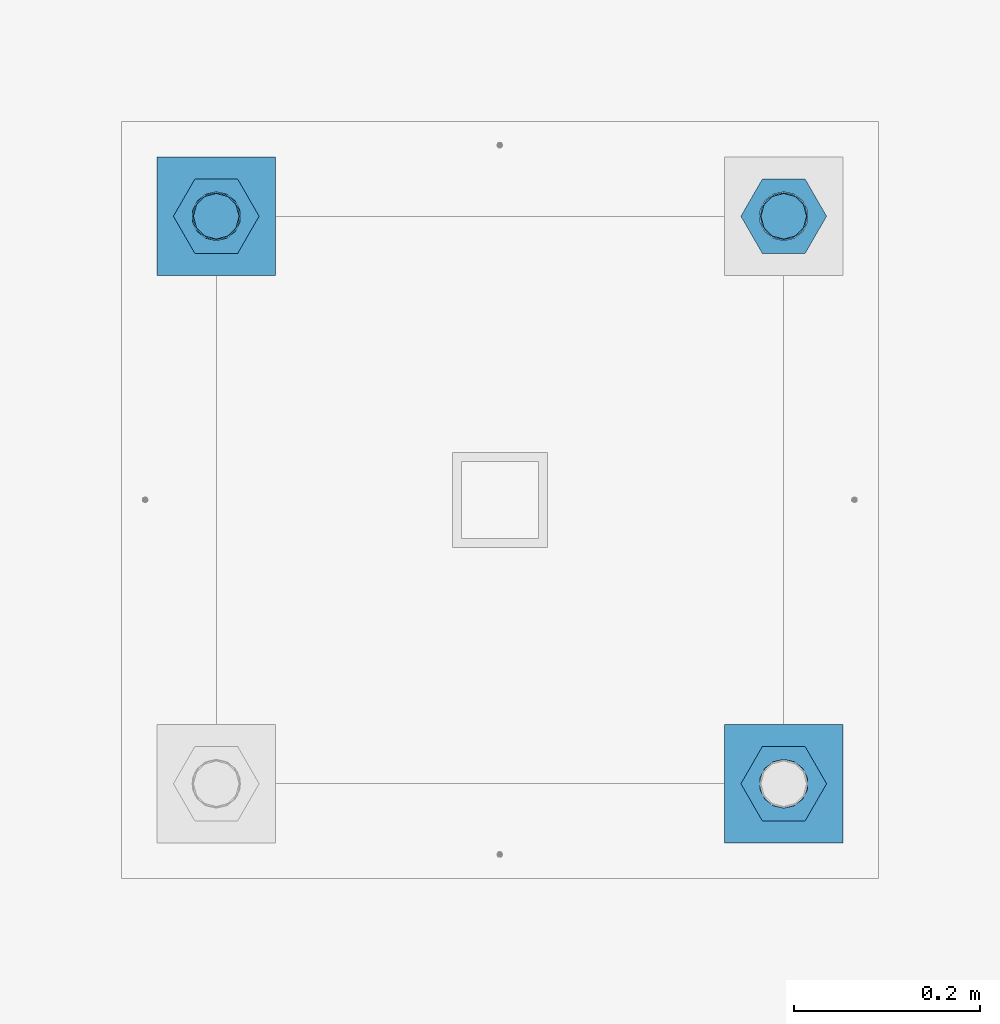
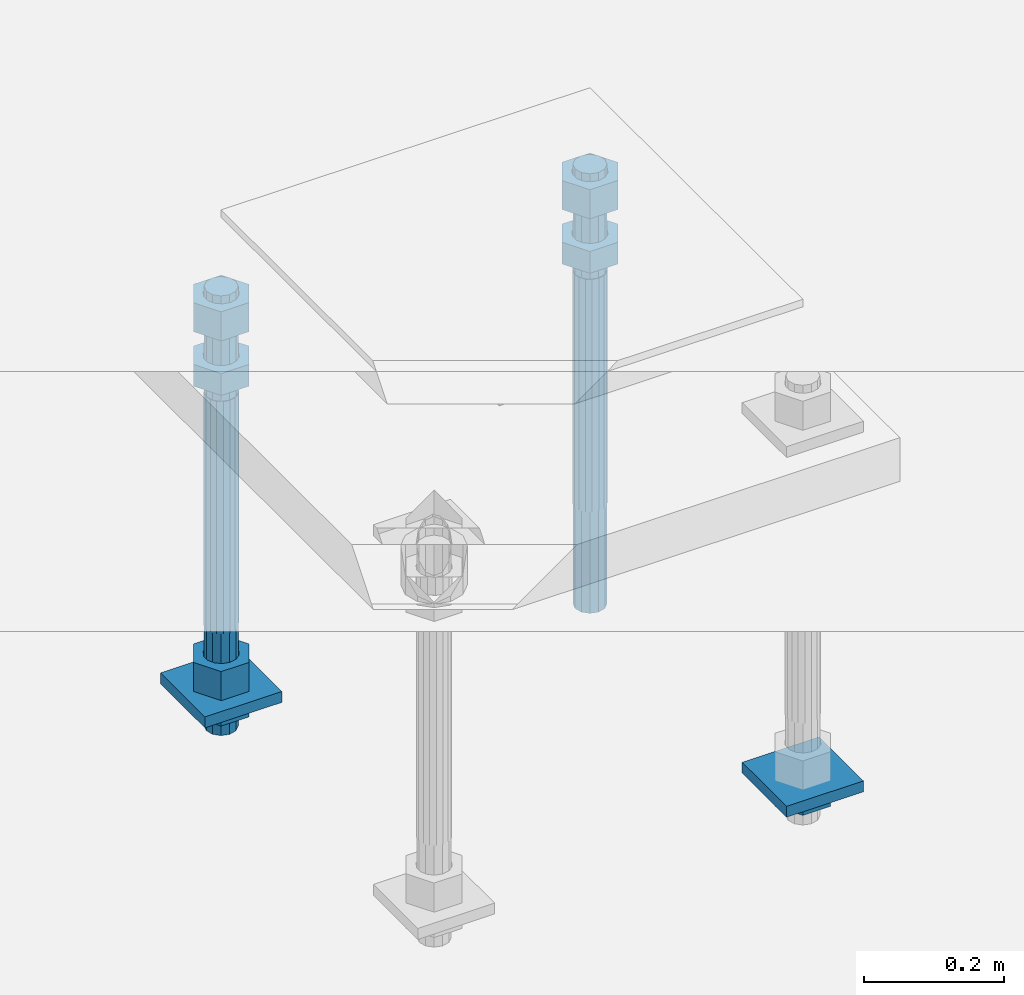
# One storey, part 2728 of 3843: 11 beams, 1 element without a shape of its own.
"""IFC2X3 building model written with IfcOpenShell, lengths in millimetres."""

from ifc_helpers import new_model, si_unit, frame, origin_with_axes, place, context, subcontext, project, spatial, faceted_brep, material, type_object, element, aggregate, save


model = new_model("IFC2X3")

# Units and contexts
model_context = context("Model", 3, precision=1e-05, world=origin_with_axes())
body_context = subcontext(model_context, "Body", "Model", "MODEL_VIEW")
ifc_project = project(units=[si_unit("LENGTHUNIT", "METRE", prefix="MILLI"), si_unit("AREAUNIT", "SQUARE_METRE"), si_unit("VOLUMEUNIT", "CUBIC_METRE"), si_unit("MASSUNIT", "GRAM", prefix="KILO"), si_unit("TIMEUNIT", "SECOND"), si_unit("PLANEANGLEUNIT", "RADIAN"), si_unit("SOLIDANGLEUNIT", "STERADIAN"), si_unit("THERMODYNAMICTEMPERATUREUNIT", "DEGREE_CELSIUS"), si_unit("LUMINOUSINTENSITYUNIT", "LUMEN")], contexts=[model_context])

# Site, building, storey
site_placement = place(None, origin_with_axes())
site = spatial("IfcSite", under=ifc_project, at=site_placement, CompositionType="ELEMENT")
building_placement = place(site_placement, origin_with_axes())
building = spatial("IfcBuilding", under=site, at=building_placement, Name="Undefined", CompositionType="ELEMENT")
storey_placement = place(building_placement, origin_with_axes())
storey = spatial("IfcBuildingStorey", under=building, at=storey_placement, Name="Undefined", CompositionType="ELEMENT", Elevation=0.0)

# Assembly, beams
assembly_placement = place(storey_placement, origin_with_axes())
assembly = element("IfcElementAssembly", 1, at=assembly_placement, inside=storey, Name="TEMPLATE", AssemblyPlace="NOTDEFINED", PredefinedType="RIGID_FRAME")
ifc_material_1 = material(Name="STEEL/A36")
beam_type_1 = type_object("IfcBeamType", PredefinedType="NOTDEFINED")
beam_1_placement = place(assembly_placement, frame((112344.2, 35750.5000015259, 29244.925), z_axis=(1.0, 0.0, 0.0), x_axis=(0.0, 1.0, 0.0)))
beam_1 = element("IfcBeam", 2, at=beam_1_placement, type_object=beam_type_1, material=ifc_material_1, Name="WASHER_PLATE", context=body_context, shape_type="Brep", body=[
    faceted_brep([(0.0, 9.52500000000146, -63.5), (0.0, 9.52500000000146, 63.5), (127.0, 9.52500000000146, 63.5), (127.0, 9.52500000000146, -63.5), (0.0, -9.52500000000146, 63.5), (127.0, -9.52500000000146, 63.5), (0.0, -9.52500000000146, -63.5), (127.0, -9.52500000000146, -63.5)], [[[0, 1, 2, 3]], [[1, 4, 5, 2]], [[4, 6, 7, 5]], [[6, 0, 3, 7]], [[5, 7, 3, 2]], [[6, 4, 1, 0]]]),
])
beam_2_placement = place(assembly_placement, frame((111734.6, 36360.1000015259, 29244.925), z_axis=(1.0, 0.0, 0.0), x_axis=(0.0, 1.0, 0.0)))
beam_2 = element("IfcBeam", 3, at=beam_2_placement, type_object=beam_type_1, material=ifc_material_1, Name="WASHER_PLATE", context=body_context, shape_type="Brep", body=[
    faceted_brep([(0.0, 9.52500000000146, -63.5), (0.0, 9.52500000000146, 63.5), (127.0, 9.52500000000146, 63.5), (127.0, 9.52500000000146, -63.5), (0.0, -9.52500000000146, 63.5), (127.0, -9.52500000000146, 63.5), (0.0, -9.52500000000146, -63.5), (127.0, -9.52500000000146, -63.5)], [[[0, 1, 2, 3]], [[1, 4, 5, 2]], [[4, 6, 7, 5]], [[6, 0, 3, 7]], [[5, 7, 3, 2]], [[6, 4, 1, 0]]]),
])
beam_type_2 = type_object("IfcBeamType", Name="2_HALF_NUT", PredefinedType="NOTDEFINED")
beam_3_placement = place(assembly_placement, frame((112344.2, 35814.0000015259, 29235.4), z_axis=(0.0, 1.0, 0.0), x_axis=(0.0, 0.0, -1.0)))
beam_3 = element("IfcBeam", 4, at=beam_3_placement, type_object=beam_type_2, material=ifc_material_1, Name="NUT", ObjectType="2_HALF_NUT", context=body_context, shape_type="Brep", body=[
    faceted_brep([(0.0, -46.0369987487793, 0.0), (0.0, -23.0184993743896, -39.869213104248), (25.4000000000015, -23.0184993743896, -39.869213104248), (25.4000000000015, -46.0369987487793, 0.0), (0.0, 23.0184993743896, -39.869213104248), (25.4000000000015, 23.0184993743896, -39.869213104248), (0.0, 46.0369987487793, 0.0), (25.4000000000015, 46.0369987487793, 0.0), (0.0, 23.0184993743896, 39.869213104248), (25.4000000000015, 23.0184993743896, 39.869213104248), (0.0, -23.0184993743896, 39.869213104248), (25.4000000000015, -23.0184993743896, 39.869213104248), (0.0, 0.0, 26.1940002441406), (0.0, 11.3650617044477, 23.5999013092805), (25.4000000000015, 11.3650617044477, 23.5999013092805), (25.4000000000015, 0.0, 26.1940002441406), (0.0, 20.4791109456419, 16.3316083006721), (25.4000000000015, 20.4791109456419, 16.3316083006721), (0.0, 25.5370200498292, 5.82867859874386), (25.4000000000015, 25.5370200498292, 5.82867859874386), (0.0, 25.5370200498292, -5.82867859874386), (25.4000000000015, 25.5370200498292, -5.82867859874386), (0.0, 20.4791109456419, -16.3316083006721), (25.4000000000015, 20.4791109456419, -16.3316083006721), (0.0, 11.3650617044477, -23.5999013092805), (25.4000000000015, 11.3650617044477, -23.5999013092805), (0.0, 0.0, -26.1940002441406), (25.4000000000015, 0.0, -26.1940002441406), (0.0, -11.3650617044477, -23.5999013092805), (25.4000000000015, -11.3650617044477, -23.5999013092805), (0.0, -20.4791109456419, -16.3316083006721), (25.4000000000015, -20.4791109456419, -16.3316083006721), (0.0, -25.5370200498292, -5.82867859874386), (25.4000000000015, -25.5370200498292, -5.82867859874386), (0.0, -25.5370200498292, 5.82867859874386), (25.4000000000015, -25.5370200498292, 5.82867859874386), (0.0, -20.4791109456419, 16.3316083006721), (25.4000000000015, -20.4791109456419, 16.3316083006721), (0.0, -11.3650617044477, 23.5999013092805), (25.4000000000015, -11.3650617044477, 23.5999013092805)], [[[0, 1, 2, 3]], [[1, 4, 5, 2]], [[4, 6, 7, 5]], [[6, 8, 9, 7]], [[8, 10, 11, 9]], [[10, 0, 3, 11]], [[12, 13, 14, 15]], [[13, 16, 17, 14]], [[16, 18, 19, 17]], [[18, 20, 21, 19]], [[20, 22, 23, 21]], [[22, 24, 25, 23]], [[24, 26, 27, 25]], [[26, 28, 29, 27]], [[28, 30, 31, 29]], [[30, 32, 33, 31]], [[32, 34, 35, 33]], [[34, 36, 37, 35]], [[36, 38, 39, 37]], [[38, 12, 15, 39]], [[5, 7, 9, 11, 3, 2], [17, 19, 21, 23, 25, 27, 29, 31, 33, 35, 37, 39, 15, 14]], [[10, 8, 6, 4, 1, 0], [38, 36, 34, 32, 30, 28, 26, 24, 22, 20, 18, 16, 13, 12]]]),
])
beam_4_placement = place(assembly_placement, frame((111734.6, 36423.6000015259, 29235.4), z_axis=(0.0, 1.0, 0.0), x_axis=(0.0, 0.0, -1.0)))
beam_4 = element("IfcBeam", 5, at=beam_4_placement, type_object=beam_type_2, material=ifc_material_1, Name="NUT", ObjectType="2_HALF_NUT", context=body_context, shape_type="Brep", body=[
    faceted_brep([(0.0, -46.0369987487793, 0.0), (0.0, -23.0184993743896, -39.869213104248), (25.4000000000015, -23.0184993743896, -39.869213104248), (25.4000000000015, -46.0369987487793, 0.0), (0.0, 23.0184993743896, -39.869213104248), (25.4000000000015, 23.0184993743896, -39.869213104248), (0.0, 46.0369987487793, 0.0), (25.4000000000015, 46.0369987487793, 0.0), (0.0, 23.0184993743896, 39.869213104248), (25.4000000000015, 23.0184993743896, 39.869213104248), (0.0, -23.0184993743896, 39.869213104248), (25.4000000000015, -23.0184993743896, 39.869213104248), (0.0, 0.0, 26.1940002441406), (0.0, 11.3650617044477, 23.5999013092805), (25.4000000000015, 11.3650617044477, 23.5999013092805), (25.4000000000015, 0.0, 26.1940002441406), (0.0, 20.4791109456419, 16.3316083006721), (25.4000000000015, 20.4791109456419, 16.3316083006721), (0.0, 25.5370200498292, 5.82867859874386), (25.4000000000015, 25.5370200498292, 5.82867859874386), (0.0, 25.5370200498292, -5.82867859874386), (25.4000000000015, 25.5370200498292, -5.82867859874386), (0.0, 20.4791109456419, -16.3316083006721), (25.4000000000015, 20.4791109456419, -16.3316083006721), (0.0, 11.3650617044477, -23.5999013092805), (25.4000000000015, 11.3650617044477, -23.5999013092805), (0.0, 0.0, -26.1940002441406), (25.4000000000015, 0.0, -26.1940002441406), (0.0, -11.3650617044477, -23.5999013092805), (25.4000000000015, -11.3650617044477, -23.5999013092805), (0.0, -20.4791109456419, -16.3316083006721), (25.4000000000015, -20.4791109456419, -16.3316083006721), (0.0, -25.5370200498292, -5.82867859874386), (25.4000000000015, -25.5370200498292, -5.82867859874386), (0.0, -25.5370200498292, 5.82867859874386), (25.4000000000015, -25.5370200498292, 5.82867859874386), (0.0, -20.4791109456419, 16.3316083006721), (25.4000000000015, -20.4791109456419, 16.3316083006721), (0.0, -11.3650617044477, 23.5999013092805), (25.4000000000015, -11.3650617044477, 23.5999013092805)], [[[0, 1, 2, 3]], [[1, 4, 5, 2]], [[4, 6, 7, 5]], [[6, 8, 9, 7]], [[8, 10, 11, 9]], [[10, 0, 3, 11]], [[12, 13, 14, 15]], [[13, 16, 17, 14]], [[16, 18, 19, 17]], [[18, 20, 21, 19]], [[20, 22, 23, 21]], [[22, 24, 25, 23]], [[24, 26, 27, 25]], [[26, 28, 29, 27]], [[28, 30, 31, 29]], [[30, 32, 33, 31]], [[32, 34, 35, 33]], [[34, 36, 37, 35]], [[36, 38, 39, 37]], [[38, 12, 15, 39]], [[5, 7, 9, 11, 3, 2], [17, 19, 21, 23, 25, 27, 29, 31, 33, 35, 37, 39, 15, 14]], [[10, 8, 6, 4, 1, 0], [38, 36, 34, 32, 30, 28, 26, 24, 22, 20, 18, 16, 13, 12]]]),
])
beam_type_3 = type_object("IfcBeamType", Name="2_HEAVY_HEX_NUT", PredefinedType="NOTDEFINED")
beam_5_placement = place(assembly_placement, frame((111734.6, 36423.6000015259, 29825.95), z_axis=(0.0, 1.0, 0.0), x_axis=(0.0, 0.0, -1.0)))
beam_5 = element("IfcBeam", 6, at=beam_5_placement, type_object=beam_type_3, material=ifc_material_1, Name="NUT", ObjectType="2_HEAVY_HEX_NUT", context=body_context, shape_type="Brep", body=[
    faceted_brep([(0.0, -46.0369987487793, 0.0), (0.0, -23.0184993743896, -39.869213104248), (38.0999999999985, -23.0184993743896, -39.869213104248), (38.0999999999985, -46.0369987487793, 0.0), (0.0, 23.0184993743896, -39.869213104248), (38.0999999999985, 23.0184993743896, -39.869213104248), (0.0, 46.0369987487793, 0.0), (38.0999999999985, 46.0369987487793, 0.0), (0.0, 23.0184993743896, 39.869213104248), (38.0999999999985, 23.0184993743896, 39.869213104248), (0.0, -23.0184993743896, 39.869213104248), (38.0999999999985, -23.0184993743896, 39.869213104248), (0.0, 0.0, 26.1940002441406), (0.0, 11.3650617044477, 23.5999013092805), (38.0999999999985, 11.3650617044477, 23.5999013092805), (38.0999999999985, 0.0, 26.1940002441406), (0.0, 20.4791109456419, 16.3316083006721), (38.0999999999985, 20.4791109456419, 16.3316083006721), (0.0, 25.5370200498292, 5.82867859874386), (38.0999999999985, 25.5370200498292, 5.82867859874386), (0.0, 25.5370200498292, -5.82867859874386), (38.0999999999985, 25.5370200498292, -5.82867859874386), (0.0, 20.4791109456419, -16.3316083006721), (38.0999999999985, 20.4791109456419, -16.3316083006721), (0.0, 11.3650617044477, -23.5999013092805), (38.0999999999985, 11.3650617044477, -23.5999013092805), (0.0, 0.0, -26.1940002441406), (38.0999999999985, 0.0, -26.1940002441406), (0.0, -11.3650617044477, -23.5999013092805), (38.0999999999985, -11.3650617044477, -23.5999013092805), (0.0, -20.4791109456419, -16.3316083006721), (38.0999999999985, -20.4791109456419, -16.3316083006721), (0.0, -25.5370200498292, -5.82867859874386), (38.0999999999985, -25.5370200498292, -5.82867859874386), (0.0, -25.5370200498292, 5.82867859874386), (38.0999999999985, -25.5370200498292, 5.82867859874386), (0.0, -20.4791109456419, 16.3316083006721), (38.0999999999985, -20.4791109456419, 16.3316083006721), (0.0, -11.3650617044477, 23.5999013092805), (38.0999999999985, -11.3650617044477, 23.5999013092805)], [[[0, 1, 2, 3]], [[1, 4, 5, 2]], [[4, 6, 7, 5]], [[6, 8, 9, 7]], [[8, 10, 11, 9]], [[10, 0, 3, 11]], [[12, 13, 14, 15]], [[13, 16, 17, 14]], [[16, 18, 19, 17]], [[18, 20, 21, 19]], [[20, 22, 23, 21]], [[22, 24, 25, 23]], [[24, 26, 27, 25]], [[26, 28, 29, 27]], [[28, 30, 31, 29]], [[30, 32, 33, 31]], [[32, 34, 35, 33]], [[34, 36, 37, 35]], [[36, 38, 39, 37]], [[38, 12, 15, 39]], [[5, 7, 9, 11, 3, 2], [17, 19, 21, 23, 25, 27, 29, 31, 33, 35, 37, 39, 15, 14]], [[10, 8, 6, 4, 1, 0], [38, 36, 34, 32, 30, 28, 26, 24, 22, 20, 18, 16, 13, 12]]]),
])
beam_6_placement = place(assembly_placement, frame((111734.6, 36423.6000015259, 29933.9), z_axis=(0.0, 1.0, 0.0), x_axis=(0.0, 0.0, -1.0)))
beam_6 = element("IfcBeam", 7, at=beam_6_placement, type_object=beam_type_3, material=ifc_material_1, Name="NUT", ObjectType="2_HEAVY_HEX_NUT", context=body_context, shape_type="Brep", body=[
    faceted_brep([(0.0, -46.0369987487793, 0.0), (0.0, -23.0184993743896, -39.869213104248), (50.7999999999993, -23.0184993743896, -39.869213104248), (50.7999999999993, -46.0369987487793, 0.0), (0.0, 23.0184993743896, -39.869213104248), (50.7999999999993, 23.0184993743896, -39.869213104248), (0.0, 46.0369987487793, 0.0), (50.7999999999993, 46.0369987487793, 0.0), (0.0, 23.0184993743896, 39.869213104248), (50.7999999999993, 23.0184993743896, 39.869213104248), (0.0, -23.0184993743896, 39.869213104248), (50.7999999999993, -23.0184993743896, 39.869213104248), (0.0, 0.0, 26.1940002441406), (0.0, 11.3650617044477, 23.5999013092805), (50.7999999999993, 11.3650617044477, 23.5999013092805), (50.7999999999993, 0.0, 26.1940002441406), (0.0, 20.4791109456419, 16.3316083006721), (50.7999999999993, 20.4791109456419, 16.3316083006721), (0.0, 25.5370200498292, 5.82867859874386), (50.7999999999993, 25.5370200498292, 5.82867859874386), (0.0, 25.5370200498292, -5.82867859874386), (50.7999999999993, 25.5370200498292, -5.82867859874386), (0.0, 20.4791109456419, -16.3316083006721), (50.7999999999993, 20.4791109456419, -16.3316083006721), (0.0, 11.3650617044477, -23.5999013092805), (50.7999999999993, 11.3650617044477, -23.5999013092805), (0.0, 0.0, -26.1940002441406), (50.7999999999993, 0.0, -26.1940002441406), (0.0, -11.3650617044477, -23.5999013092805), (50.7999999999993, -11.3650617044477, -23.5999013092805), (0.0, -20.4791109456419, -16.3316083006721), (50.7999999999993, -20.4791109456419, -16.3316083006721), (0.0, -25.5370200498292, -5.82867859874386), (50.7999999999993, -25.5370200498292, -5.82867859874386), (0.0, -25.5370200498292, 5.82867859874386), (50.7999999999993, -25.5370200498292, 5.82867859874386), (0.0, -20.4791109456419, 16.3316083006721), (50.7999999999993, -20.4791109456419, 16.3316083006721), (0.0, -11.3650617044477, 23.5999013092805), (50.7999999999993, -11.3650617044477, 23.5999013092805)], [[[0, 1, 2, 3]], [[1, 4, 5, 2]], [[4, 6, 7, 5]], [[6, 8, 9, 7]], [[8, 10, 11, 9]], [[10, 0, 3, 11]], [[12, 13, 14, 15]], [[13, 16, 17, 14]], [[16, 18, 19, 17]], [[18, 20, 21, 19]], [[20, 22, 23, 21]], [[22, 24, 25, 23]], [[24, 26, 27, 25]], [[26, 28, 29, 27]], [[28, 30, 31, 29]], [[30, 32, 33, 31]], [[32, 34, 35, 33]], [[34, 36, 37, 35]], [[36, 38, 39, 37]], [[38, 12, 15, 39]], [[5, 7, 9, 11, 3, 2], [17, 19, 21, 23, 25, 27, 29, 31, 33, 35, 37, 39, 15, 14]], [[10, 8, 6, 4, 1, 0], [38, 36, 34, 32, 30, 28, 26, 24, 22, 20, 18, 16, 13, 12]]]),
])
beam_7_placement = place(assembly_placement, frame((111734.6, 36423.6000015259, 29305.25), z_axis=(0.0, 1.0, 0.0), x_axis=(0.0, 0.0, -1.0)))
beam_7 = element("IfcBeam", 8, at=beam_7_placement, type_object=beam_type_3, material=ifc_material_1, Name="NUT", ObjectType="2_HEAVY_HEX_NUT", context=body_context, shape_type="Brep", body=[
    faceted_brep([(0.0, -46.0369987487793, 0.0), (0.0, -23.0184993743896, -39.869213104248), (50.7999999999993, -23.0184993743896, -39.869213104248), (50.7999999999993, -46.0369987487793, 0.0), (0.0, 23.0184993743896, -39.869213104248), (50.7999999999993, 23.0184993743896, -39.869213104248), (0.0, 46.0369987487793, 0.0), (50.7999999999993, 46.0369987487793, 0.0), (0.0, 23.0184993743896, 39.869213104248), (50.7999999999993, 23.0184993743896, 39.869213104248), (0.0, -23.0184993743896, 39.869213104248), (50.7999999999993, -23.0184993743896, 39.869213104248), (0.0, 0.0, 26.1940002441406), (0.0, 11.3650617044477, 23.5999013092805), (50.7999999999993, 11.3650617044477, 23.5999013092805), (50.7999999999993, 0.0, 26.1940002441406), (0.0, 20.4791109456419, 16.3316083006721), (50.7999999999993, 20.4791109456419, 16.3316083006721), (0.0, 25.5370200498292, 5.82867859874386), (50.7999999999993, 25.5370200498292, 5.82867859874386), (0.0, 25.5370200498292, -5.82867859874386), (50.7999999999993, 25.5370200498292, -5.82867859874386), (0.0, 20.4791109456419, -16.3316083006721), (50.7999999999993, 20.4791109456419, -16.3316083006721), (0.0, 11.3650617044477, -23.5999013092805), (50.7999999999993, 11.3650617044477, -23.5999013092805), (0.0, 0.0, -26.1940002441406), (50.7999999999993, 0.0, -26.1940002441406), (0.0, -11.3650617044477, -23.5999013092805), (50.7999999999993, -11.3650617044477, -23.5999013092805), (0.0, -20.4791109456419, -16.3316083006721), (50.7999999999993, -20.4791109456419, -16.3316083006721), (0.0, -25.5370200498292, -5.82867859874386), (50.7999999999993, -25.5370200498292, -5.82867859874386), (0.0, -25.5370200498292, 5.82867859874386), (50.7999999999993, -25.5370200498292, 5.82867859874386), (0.0, -20.4791109456419, 16.3316083006721), (50.7999999999993, -20.4791109456419, 16.3316083006721), (0.0, -11.3650617044477, 23.5999013092805), (50.7999999999993, -11.3650617044477, 23.5999013092805)], [[[0, 1, 2, 3]], [[1, 4, 5, 2]], [[4, 6, 7, 5]], [[6, 8, 9, 7]], [[8, 10, 11, 9]], [[10, 0, 3, 11]], [[12, 13, 14, 15]], [[13, 16, 17, 14]], [[16, 18, 19, 17]], [[18, 20, 21, 19]], [[20, 22, 23, 21]], [[22, 24, 25, 23]], [[24, 26, 27, 25]], [[26, 28, 29, 27]], [[28, 30, 31, 29]], [[30, 32, 33, 31]], [[32, 34, 35, 33]], [[34, 36, 37, 35]], [[36, 38, 39, 37]], [[38, 12, 15, 39]], [[5, 7, 9, 11, 3, 2], [17, 19, 21, 23, 25, 27, 29, 31, 33, 35, 37, 39, 15, 14]], [[10, 8, 6, 4, 1, 0], [38, 36, 34, 32, 30, 28, 26, 24, 22, 20, 18, 16, 13, 12]]]),
])
beam_8_placement = place(assembly_placement, frame((112344.2, 36423.6000015259, 29825.95), z_axis=(0.0, 1.0, 0.0), x_axis=(0.0, 0.0, -1.0)))
beam_8 = element("IfcBeam", 9, at=beam_8_placement, type_object=beam_type_3, material=ifc_material_1, Name="NUT", ObjectType="2_HEAVY_HEX_NUT", context=body_context, shape_type="Brep", body=[
    faceted_brep([(0.0, -46.0369987487793, 0.0), (0.0, -23.0184993743896, -39.869213104248), (38.0999999999985, -23.0184993743896, -39.869213104248), (38.0999999999985, -46.0369987487793, 0.0), (0.0, 23.0184993743896, -39.869213104248), (38.0999999999985, 23.0184993743896, -39.869213104248), (0.0, 46.0369987487793, 0.0), (38.0999999999985, 46.0369987487793, 0.0), (0.0, 23.0184993743896, 39.869213104248), (38.0999999999985, 23.0184993743896, 39.869213104248), (0.0, -23.0184993743896, 39.869213104248), (38.0999999999985, -23.0184993743896, 39.869213104248), (0.0, 0.0, 26.1940002441406), (0.0, 11.3650617044477, 23.5999013092805), (38.0999999999985, 11.3650617044477, 23.5999013092805), (38.0999999999985, 0.0, 26.1940002441406), (0.0, 20.4791109456419, 16.3316083006721), (38.0999999999985, 20.4791109456419, 16.3316083006721), (0.0, 25.5370200498292, 5.82867859874386), (38.0999999999985, 25.5370200498292, 5.82867859874386), (0.0, 25.5370200498292, -5.82867859874386), (38.0999999999985, 25.5370200498292, -5.82867859874386), (0.0, 20.4791109456419, -16.3316083006721), (38.0999999999985, 20.4791109456419, -16.3316083006721), (0.0, 11.3650617044477, -23.5999013092805), (38.0999999999985, 11.3650617044477, -23.5999013092805), (0.0, 0.0, -26.1940002441406), (38.0999999999985, 0.0, -26.1940002441406), (0.0, -11.3650617044477, -23.5999013092805), (38.0999999999985, -11.3650617044477, -23.5999013092805), (0.0, -20.4791109456419, -16.3316083006721), (38.0999999999985, -20.4791109456419, -16.3316083006721), (0.0, -25.5370200498292, -5.82867859874386), (38.0999999999985, -25.5370200498292, -5.82867859874386), (0.0, -25.5370200498292, 5.82867859874386), (38.0999999999985, -25.5370200498292, 5.82867859874386), (0.0, -20.4791109456419, 16.3316083006721), (38.0999999999985, -20.4791109456419, 16.3316083006721), (0.0, -11.3650617044477, 23.5999013092805), (38.0999999999985, -11.3650617044477, 23.5999013092805)], [[[0, 1, 2, 3]], [[1, 4, 5, 2]], [[4, 6, 7, 5]], [[6, 8, 9, 7]], [[8, 10, 11, 9]], [[10, 0, 3, 11]], [[12, 13, 14, 15]], [[13, 16, 17, 14]], [[16, 18, 19, 17]], [[18, 20, 21, 19]], [[20, 22, 23, 21]], [[22, 24, 25, 23]], [[24, 26, 27, 25]], [[26, 28, 29, 27]], [[28, 30, 31, 29]], [[30, 32, 33, 31]], [[32, 34, 35, 33]], [[34, 36, 37, 35]], [[36, 38, 39, 37]], [[38, 12, 15, 39]], [[5, 7, 9, 11, 3, 2], [17, 19, 21, 23, 25, 27, 29, 31, 33, 35, 37, 39, 15, 14]], [[10, 8, 6, 4, 1, 0], [38, 36, 34, 32, 30, 28, 26, 24, 22, 20, 18, 16, 13, 12]]]),
])
beam_9_placement = place(assembly_placement, frame((112344.2, 36423.6000015259, 29933.9), z_axis=(0.0, 1.0, 0.0), x_axis=(0.0, 0.0, -1.0)))
beam_9 = element("IfcBeam", 10, at=beam_9_placement, type_object=beam_type_3, material=ifc_material_1, Name="NUT", ObjectType="2_HEAVY_HEX_NUT", context=body_context, shape_type="Brep", body=[
    faceted_brep([(0.0, -46.0369987487793, 0.0), (0.0, -23.0184993743896, -39.869213104248), (50.7999999999993, -23.0184993743896, -39.869213104248), (50.7999999999993, -46.0369987487793, 0.0), (0.0, 23.0184993743896, -39.869213104248), (50.7999999999993, 23.0184993743896, -39.869213104248), (0.0, 46.0369987487793, 0.0), (50.7999999999993, 46.0369987487793, 0.0), (0.0, 23.0184993743896, 39.869213104248), (50.7999999999993, 23.0184993743896, 39.869213104248), (0.0, -23.0184993743896, 39.869213104248), (50.7999999999993, -23.0184993743896, 39.869213104248), (0.0, 0.0, 26.1940002441406), (0.0, 11.3650617044477, 23.5999013092805), (50.7999999999993, 11.3650617044477, 23.5999013092805), (50.7999999999993, 0.0, 26.1940002441406), (0.0, 20.4791109456419, 16.3316083006721), (50.7999999999993, 20.4791109456419, 16.3316083006721), (0.0, 25.5370200498292, 5.82867859874386), (50.7999999999993, 25.5370200498292, 5.82867859874386), (0.0, 25.5370200498292, -5.82867859874386), (50.7999999999993, 25.5370200498292, -5.82867859874386), (0.0, 20.4791109456419, -16.3316083006721), (50.7999999999993, 20.4791109456419, -16.3316083006721), (0.0, 11.3650617044477, -23.5999013092805), (50.7999999999993, 11.3650617044477, -23.5999013092805), (0.0, 0.0, -26.1940002441406), (50.7999999999993, 0.0, -26.1940002441406), (0.0, -11.3650617044477, -23.5999013092805), (50.7999999999993, -11.3650617044477, -23.5999013092805), (0.0, -20.4791109456419, -16.3316083006721), (50.7999999999993, -20.4791109456419, -16.3316083006721), (0.0, -25.5370200498292, -5.82867859874386), (50.7999999999993, -25.5370200498292, -5.82867859874386), (0.0, -25.5370200498292, 5.82867859874386), (50.7999999999993, -25.5370200498292, 5.82867859874386), (0.0, -20.4791109456419, 16.3316083006721), (50.7999999999993, -20.4791109456419, 16.3316083006721), (0.0, -11.3650617044477, 23.5999013092805), (50.7999999999993, -11.3650617044477, 23.5999013092805)], [[[0, 1, 2, 3]], [[1, 4, 5, 2]], [[4, 6, 7, 5]], [[6, 8, 9, 7]], [[8, 10, 11, 9]], [[10, 0, 3, 11]], [[12, 13, 14, 15]], [[13, 16, 17, 14]], [[16, 18, 19, 17]], [[18, 20, 21, 19]], [[20, 22, 23, 21]], [[22, 24, 25, 23]], [[24, 26, 27, 25]], [[26, 28, 29, 27]], [[28, 30, 31, 29]], [[30, 32, 33, 31]], [[32, 34, 35, 33]], [[34, 36, 37, 35]], [[36, 38, 39, 37]], [[38, 12, 15, 39]], [[5, 7, 9, 11, 3, 2], [17, 19, 21, 23, 25, 27, 29, 31, 33, 35, 37, 39, 15, 14]], [[10, 8, 6, 4, 1, 0], [38, 36, 34, 32, 30, 28, 26, 24, 22, 20, 18, 16, 13, 12]]]),
])
ifc_material_2 = material()
beam_type_4 = type_object("IfcBeamType", PredefinedType="NOTDEFINED")
beam_10_placement = place(assembly_placement, frame((111734.6, 36423.6000015259, 29762.45), z_axis=(0.0, 1.0, 0.0), x_axis=(0.0, 0.0, -1.0)))
beam_10 = element("IfcBeam", 11, at=beam_10_placement, type_object=beam_type_4, material=ifc_material_2, Name="ANCHOR_ROD", context=body_context, shape_type="Brep", body=[
    faceted_brep([(-184.150000000001, -21.217622392709, 12.25), (-184.150000000001, -12.2499999999854, 21.2176223927163), (-184.150000000001, 1.45519152283669e-11, 24.5), (-184.150000000001, 12.2500000000146, 21.2176223927163), (-184.150000000001, 21.2176223927381, 12.25), (-184.150000000001, 24.5000000000146, 0.0), (-184.150000000001, 21.2176223927381, -12.25), (-184.150000000001, 12.2500000000146, -21.2176223927163), (-184.150000000001, 1.45519152283669e-11, -24.5), (-184.150000000001, -12.2499999999854, -21.2176223927163), (-184.150000000001, -21.217622392709, -12.25), (-184.150000000001, -24.4999999999854, 0.0), (0.0, 24.5000000000146, 0.0), (0.0, 21.2176223927381, -12.25), (0.0, 12.2500000000146, -21.2176223927163), (0.0, 1.45519152283669e-11, -24.5), (0.0, -12.2499999999854, -21.2176223927163), (0.0, -21.217622392709, -12.25), (0.0, -24.4999999999854, 0.0), (0.0, -21.217622392709, 12.25), (0.0, -12.2499999999854, 21.2176223927163), (0.0, 1.45519152283669e-11, 24.5), (0.0, 12.2500000000146, 21.2176223927163), (0.0, 21.2176223927381, 12.25), (0.0, -23.4665401257807, 9.72015918207035), (0.0, -17.9605122421344, 17.9605122421417), (0.0, -9.72015918207762, 23.466540125788), (0.0, 0.0, 25.4000000000015), (0.0, 9.72015918207762, 23.466540125788), (0.0, 17.9605122421344, 17.9605122421417), (0.0, 23.4665401257807, 9.72015918207035), (0.0, 25.3999996185303, 0.0), (0.0, 23.4665401257807, -9.72015918207035), (0.0, 17.9605122421344, -17.9605122421417), (0.0, 9.72015918207762, -23.466540125788), (0.0, 0.0, -25.4000000000015), (0.0, -9.72015918207762, -23.466540125788), (0.0, -17.9605122421344, -17.9605122421417), (0.0, -23.4665401257807, -9.72015918207035), (0.0, -25.3999996185303, 0.0), (406.399999999998, -25.3999999999942, 0.0), (406.399999999998, -23.4665401257807, 9.72015918207035), (406.399999999998, -17.9605122421344, 17.9605122421417), (406.399999999998, -9.72015918207762, 23.466540125788), (406.399999999998, 0.0, 25.4000000000015), (406.399999999998, 9.72015918207762, 23.466540125788), (406.399999999998, 17.9605122421344, 17.9605122421417), (406.399999999998, 23.4665401257807, 9.72015918207035), (406.399999999998, 25.3999999999942, 0.0), (406.399999999998, 23.4665401257807, -9.72015918207035), (406.399999999998, 17.9605122421344, -17.9605122421417), (406.399999999998, 9.72015918207762, -23.466540125788), (406.399999999998, 0.0, -25.4000000000015), (406.399999999998, -9.72015918207762, -23.466540125788), (406.399999999998, -17.9605122421344, -17.9605122421417), (406.399999999998, -23.4665401257807, -9.72015918207035), (406.399999999998, -12.2499999999854, 21.2176223927163), (406.399999999998, 1.45519152283669e-11, 24.5), (406.399999999998, 12.2500000000146, 21.2176223927163), (406.399999999998, 21.2176223927381, 12.25), (406.399999999998, 24.5000000000146, 0.0), (406.399999999998, 21.2176223927381, -12.25), (406.399999999998, 12.2500000000146, -21.2176223927163), (406.399999999998, 1.45519152283669e-11, -24.5), (406.399999999998, -12.2499999999854, -21.2176223927163), (406.399999999998, -21.217622392709, -12.25), (406.399999999998, -24.4999999999854, 0.0), (406.399999999998, -21.217622392709, 12.25), (584.200000000001, -12.2499999999854, -21.2176223927163), (584.200000000001, 1.45519152283669e-11, -24.5), (584.200000000001, 12.2500000000146, -21.2176223927163), (584.200000000001, 21.2176223927381, -12.25), (584.200000000001, 24.5000000000146, 0.0), (584.200000000001, 21.2176223927381, 12.25), (584.200000000001, 12.2500000000146, 21.2176223927163), (584.200000000001, 1.45519152283669e-11, 24.5), (584.200000000001, -12.2499999999854, 21.2176223927163), (584.200000000001, -21.217622392709, 12.25), (584.200000000001, -24.4999999999854, 0.0), (584.200000000001, -21.217622392709, -12.25)], [[[0, 1, 2, 3, 4, 5, 6, 7, 8, 9, 10, 11]], [[6, 5, 12, 13]], [[7, 6, 13, 14]], [[8, 7, 14, 15]], [[9, 8, 15, 16]], [[10, 9, 16, 17]], [[11, 10, 17, 18]], [[0, 11, 18, 19]], [[1, 0, 19, 20]], [[2, 1, 20, 21]], [[3, 2, 21, 22]], [[4, 3, 22, 23]], [[5, 4, 23, 12]], [[24, 25, 26, 27, 28, 29, 30, 31, 32, 33, 34, 35, 36, 37, 38, 39], [22, 21, 20, 19, 18, 17, 16, 15, 14, 13, 12, 23]], [[24, 39, 40, 41]], [[25, 24, 41, 42]], [[26, 25, 42, 43]], [[27, 26, 43, 44]], [[28, 27, 44, 45]], [[29, 28, 45, 46]], [[30, 29, 46, 47]], [[31, 30, 47, 48]], [[32, 31, 48, 49]], [[33, 32, 49, 50]], [[34, 33, 50, 51]], [[35, 34, 51, 52]], [[36, 35, 52, 53]], [[37, 36, 53, 54]], [[38, 37, 54, 55]], [[39, 38, 55, 40]], [[54, 53, 52, 51, 50, 49, 48, 47, 46, 45, 44, 43, 42, 41, 40, 55], [56, 57, 58, 59, 60, 61, 62, 63, 64, 65, 66, 67]], [[68, 69, 70, 71, 72, 73, 74, 75, 76, 77, 78, 79]], [[76, 75, 57, 56]], [[77, 76, 56, 67]], [[78, 77, 67, 66]], [[79, 78, 66, 65]], [[68, 79, 65, 64]], [[69, 68, 64, 63]], [[70, 69, 63, 62]], [[71, 70, 62, 61]], [[72, 71, 61, 60]], [[73, 72, 60, 59]], [[74, 73, 59, 58]], [[75, 74, 58, 57]]]),
])
beam_11_placement = place(assembly_placement, frame((112344.2, 36423.6000015259, 29762.45), z_axis=(0.0, 1.0, 0.0), x_axis=(0.0, 0.0, -1.0)))
beam_11 = element("IfcBeam", 12, at=beam_11_placement, type_object=beam_type_4, material=ifc_material_2, Name="ANCHOR_ROD", context=body_context, shape_type="Brep", body=[
    faceted_brep([(-184.150000000001, -21.217622392709, 12.25), (-184.150000000001, -12.2499999999854, 21.2176223927163), (-184.150000000001, 1.45519152283669e-11, 24.5), (-184.150000000001, 12.2500000000146, 21.2176223927163), (-184.150000000001, 21.2176223927381, 12.25), (-184.150000000001, 24.5000000000146, 0.0), (-184.150000000001, 21.2176223927381, -12.25), (-184.150000000001, 12.2500000000146, -21.2176223927163), (-184.150000000001, 1.45519152283669e-11, -24.5), (-184.150000000001, -12.2499999999854, -21.2176223927163), (-184.150000000001, -21.217622392709, -12.25), (-184.150000000001, -24.4999999999854, 0.0), (0.0, 24.5000000000146, 0.0), (0.0, 21.2176223927381, -12.25), (0.0, 12.2500000000146, -21.2176223927163), (0.0, 1.45519152283669e-11, -24.5), (0.0, -12.2499999999854, -21.2176223927163), (0.0, -21.217622392709, -12.25), (0.0, -24.4999999999854, 0.0), (0.0, -21.217622392709, 12.25), (0.0, -12.2499999999854, 21.2176223927163), (0.0, 1.45519152283669e-11, 24.5), (0.0, 12.2500000000146, 21.2176223927163), (0.0, 21.2176223927381, 12.25), (0.0, -23.4665401257807, 9.72015918207035), (0.0, -17.9605122421344, 17.9605122421417), (0.0, -9.72015918207762, 23.466540125788), (0.0, 0.0, 25.4000000000015), (0.0, 9.72015918207762, 23.466540125788), (0.0, 17.9605122421344, 17.9605122421417), (0.0, 23.4665401257807, 9.72015918207035), (0.0, 25.3999996185303, 0.0), (0.0, 23.4665401257807, -9.72015918207035), (0.0, 17.9605122421344, -17.9605122421417), (0.0, 9.72015918207762, -23.466540125788), (0.0, 0.0, -25.4000000000015), (0.0, -9.72015918207762, -23.466540125788), (0.0, -17.9605122421344, -17.9605122421417), (0.0, -23.4665401257807, -9.72015918207035), (0.0, -25.3999996185303, 0.0), (406.399999999998, -25.3999999999942, 0.0), (406.399999999998, -23.4665401257807, 9.72015918207035), (406.399999999998, -17.9605122421344, 17.9605122421417), (406.399999999998, -9.72015918207762, 23.466540125788), (406.399999999998, 0.0, 25.4000000000015), (406.399999999998, 9.72015918207762, 23.466540125788), (406.399999999998, 17.9605122421344, 17.9605122421417), (406.399999999998, 23.4665401257807, 9.72015918207035), (406.399999999998, 25.3999999999942, 0.0), (406.399999999998, 23.4665401257807, -9.72015918207035), (406.399999999998, 17.9605122421344, -17.9605122421417), (406.399999999998, 9.72015918207762, -23.466540125788), (406.399999999998, 0.0, -25.4000000000015), (406.399999999998, -9.72015918207762, -23.466540125788), (406.399999999998, -17.9605122421344, -17.9605122421417), (406.399999999998, -23.4665401257807, -9.72015918207035), (406.399999999998, -12.2499999999854, 21.2176223927163), (406.399999999998, 1.45519152283669e-11, 24.5), (406.399999999998, 12.2500000000146, 21.2176223927163), (406.399999999998, 21.2176223927381, 12.25), (406.399999999998, 24.5000000000146, 0.0), (406.399999999998, 21.2176223927381, -12.25), (406.399999999998, 12.2500000000146, -21.2176223927163), (406.399999999998, 1.45519152283669e-11, -24.5), (406.399999999998, -12.2499999999854, -21.2176223927163), (406.399999999998, -21.217622392709, -12.25), (406.399999999998, -24.4999999999854, 0.0), (406.399999999998, -21.217622392709, 12.25), (584.200000000001, -12.2499999999854, -21.2176223927163), (584.200000000001, 1.45519152283669e-11, -24.5), (584.200000000001, 12.2500000000146, -21.2176223927163), (584.200000000001, 21.2176223927381, -12.25), (584.200000000001, 24.5000000000146, 0.0), (584.200000000001, 21.2176223927381, 12.25), (584.200000000001, 12.2500000000146, 21.2176223927163), (584.200000000001, 1.45519152283669e-11, 24.5), (584.200000000001, -12.2499999999854, 21.2176223927163), (584.200000000001, -21.217622392709, 12.25), (584.200000000001, -24.4999999999854, 0.0), (584.200000000001, -21.217622392709, -12.25)], [[[0, 1, 2, 3, 4, 5, 6, 7, 8, 9, 10, 11]], [[6, 5, 12, 13]], [[7, 6, 13, 14]], [[8, 7, 14, 15]], [[9, 8, 15, 16]], [[10, 9, 16, 17]], [[11, 10, 17, 18]], [[0, 11, 18, 19]], [[1, 0, 19, 20]], [[2, 1, 20, 21]], [[3, 2, 21, 22]], [[4, 3, 22, 23]], [[5, 4, 23, 12]], [[24, 25, 26, 27, 28, 29, 30, 31, 32, 33, 34, 35, 36, 37, 38, 39], [22, 21, 20, 19, 18, 17, 16, 15, 14, 13, 12, 23]], [[24, 39, 40, 41]], [[25, 24, 41, 42]], [[26, 25, 42, 43]], [[27, 26, 43, 44]], [[28, 27, 44, 45]], [[29, 28, 45, 46]], [[30, 29, 46, 47]], [[31, 30, 47, 48]], [[32, 31, 48, 49]], [[33, 32, 49, 50]], [[34, 33, 50, 51]], [[35, 34, 51, 52]], [[36, 35, 52, 53]], [[37, 36, 53, 54]], [[38, 37, 54, 55]], [[39, 38, 55, 40]], [[54, 53, 52, 51, 50, 49, 48, 47, 46, 45, 44, 43, 42, 41, 40, 55], [56, 57, 58, 59, 60, 61, 62, 63, 64, 65, 66, 67]], [[68, 69, 70, 71, 72, 73, 74, 75, 76, 77, 78, 79]], [[76, 75, 57, 56]], [[77, 76, 56, 67]], [[78, 77, 67, 66]], [[79, 78, 66, 65]], [[68, 79, 65, 64]], [[69, 68, 64, 63]], [[70, 69, 63, 62]], [[71, 70, 62, 61]], [[72, 71, 61, 60]], [[73, 72, 60, 59]], [[74, 73, 59, 58]], [[75, 74, 58, 57]]]),
])
aggregate(assembly, [beam_3, beam_1, beam_10, beam_5, beam_6, beam_7, beam_4, beam_2, beam_11, beam_8, beam_9])

save(model, "model.ifc")
